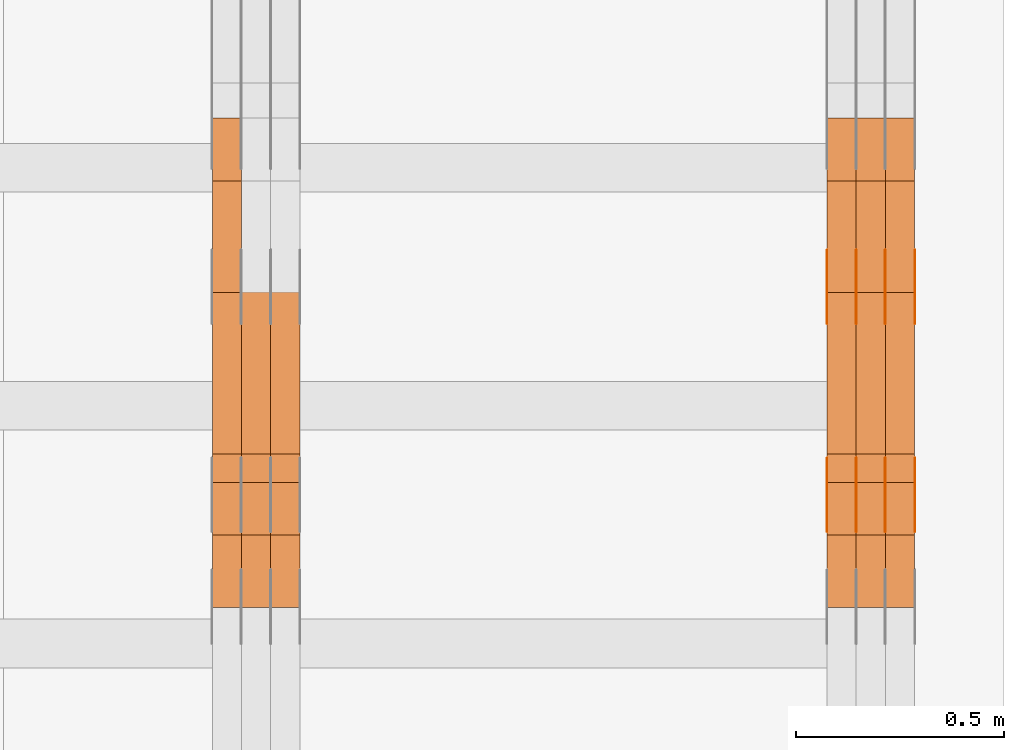
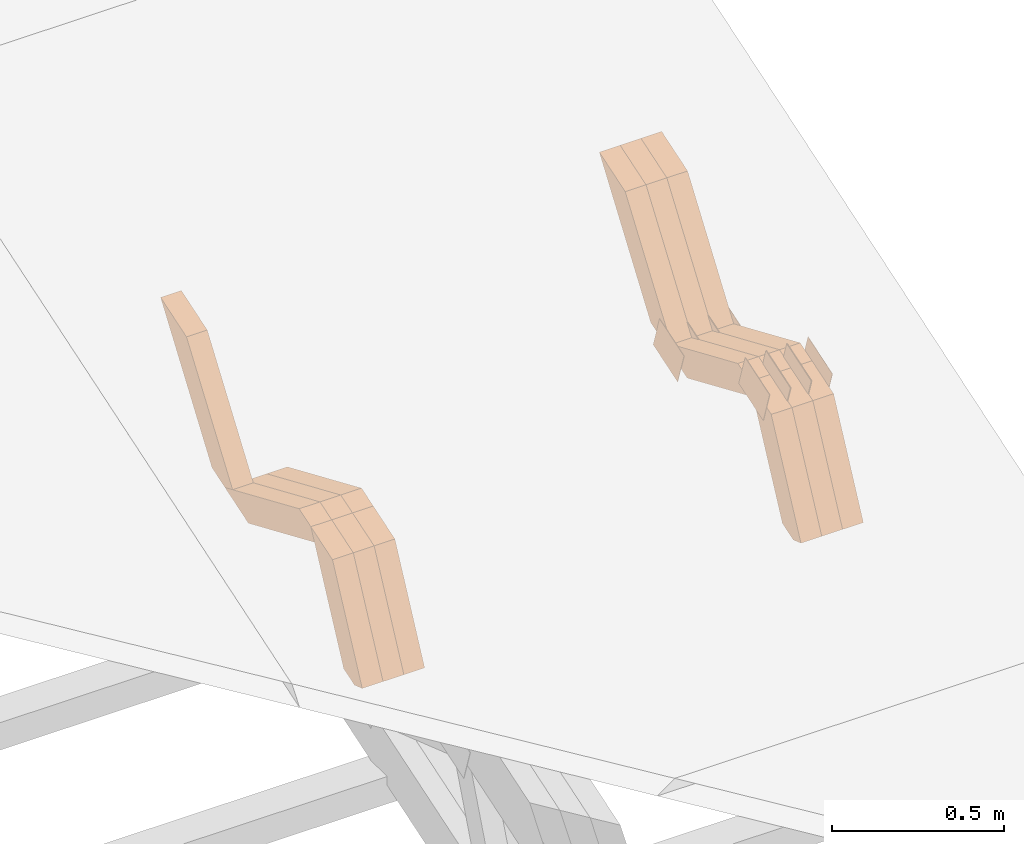
# One storey, part 313 of 385: 28 proxies.
"""IFC2X3 building model written with IfcOpenShell, lengths in millimetres."""

from ifc_helpers import new_model, entity, si_unit, converted_unit, derived_unit, direction, frame, origin, place, context, subcontext, project, spatial, polyline, outline, extrude, source, transform, mapped, material, type_object, type_shapes, element, save


model = new_model("IFC2X3")

# Units and contexts
model_context = context("Model", 3, precision=0.01, world=origin(), true_north=direction((6.12303176911189e-17, 1.0)))
body_context = subcontext(model_context, "Body", "Model", "MODEL_VIEW")
ifc_project = project(units=[si_unit("LENGTHUNIT", "METRE", prefix="MILLI"), si_unit("AREAUNIT", "SQUARE_METRE"), si_unit("VOLUMEUNIT", "CUBIC_METRE"), converted_unit("PLANEANGLEUNIT", "DEGREE", entity("IfcRatioMeasure", 0.0174532925199433), si_unit("PLANEANGLEUNIT", "RADIAN"), dimensions=[0, 0, 0, 0, 0, 0, 0]), si_unit("MASSUNIT", "GRAM", prefix="KILO"), derived_unit("MASSDENSITYUNIT", [(si_unit("MASSUNIT", "GRAM", prefix="KILO"), 1), (si_unit("LENGTHUNIT", "METRE"), -3)]), si_unit("TIMEUNIT", "SECOND"), si_unit("FREQUENCYUNIT", "HERTZ"), si_unit("THERMODYNAMICTEMPERATUREUNIT", "DEGREE_CELSIUS"), derived_unit("THERMALTRANSMITTANCEUNIT", [(si_unit("MASSUNIT", "GRAM", prefix="KILO"), 1), (si_unit("THERMODYNAMICTEMPERATUREUNIT", "KELVIN"), -1), (si_unit("TIMEUNIT", "SECOND"), -3)]), derived_unit("VOLUMETRICFLOWRATEUNIT", [(si_unit("LENGTHUNIT", "METRE"), 3), (si_unit("TIMEUNIT", "SECOND"), -1)]), si_unit("ELECTRICCURRENTUNIT", "AMPERE"), si_unit("ELECTRICVOLTAGEUNIT", "VOLT"), si_unit("POWERUNIT", "WATT"), si_unit("FORCEUNIT", "NEWTON", prefix="KILO"), si_unit("ILLUMINANCEUNIT", "LUX"), si_unit("LUMINOUSFLUXUNIT", "LUMEN"), si_unit("LUMINOUSINTENSITYUNIT", "CANDELA"), derived_unit("USERDEFINED", [(si_unit("MASSUNIT", "GRAM", prefix="KILO"), -1), (si_unit("LENGTHUNIT", "METRE"), -2), (si_unit("TIMEUNIT", "SECOND"), 3), (si_unit("LUMINOUSFLUXUNIT", "LUMEN"), 1)]), derived_unit("LINEARVELOCITYUNIT", [(si_unit("LENGTHUNIT", "METRE"), 1), (si_unit("TIMEUNIT", "SECOND"), -1)]), si_unit("PRESSUREUNIT", "PASCAL"), derived_unit("USERDEFINED", [(si_unit("LENGTHUNIT", "METRE"), -2), (si_unit("MASSUNIT", "GRAM", prefix="KILO"), 1), (si_unit("TIMEUNIT", "SECOND"), -2)])], contexts=[model_context])

# Site, building, storey
site_placement = place(None, origin())
site = spatial("IfcSite", under=ifc_project, at=site_placement, CompositionType="ELEMENT")
building_placement = place(site_placement, origin())
building = spatial("IfcBuilding", under=site, at=building_placement, CompositionType="ELEMENT")
storey_placement = place(building_placement, origin())
storey = spatial("IfcBuildingStorey", under=building, at=storey_placement, Name="Default", CompositionType="ELEMENT", Elevation=0.0)

# Proxies
ifc_material_1 = material(Name="IfcSurfaceStyle #620956")
building_element_proxy_type_1 = type_object("IfcBuildingElementProxyType", PredefinedType="NOTDEFINED", material=ifc_material_1)
shared_shape_1 = source(origin(), body_context, "Body", "SweptSolid", [
    extrude(outline(polyline([(-74.9998565677169, -60.0000596852269), (74.9998794200137, -60.0000596852269), (74.9998565677151, 60.0000596852269), (-74.9998794200119, 60.0000596852269), (-74.9998565677169, -60.0000596852269)])), frame((74.9998794200137, 60.0000596852269, 0.0), z_axis=(0.0, 0.0, 1.0), x_axis=(-1.0, 0.0, 0.0)), (0.0, 0.0, 1.0), 1.3),
])
type_shapes(building_element_proxy_type_1, [shared_shape_1])
proxy_1_placement = place(building_placement, frame((49861.3, 7527.6269081625, 1621.97418552253), z_axis=(-1.0, 0.0, 0.0), x_axis=(0.0, 0.951056516295124, 0.309016994375039)))
element("IfcBuildingElementProxy", 1, at=proxy_1_placement, inside=storey, type_object=building_element_proxy_type_1, material=ifc_material_1, context=body_context, shape_type="MappedRepresentation", body=[
    mapped(shared_shape_1, transform((0.0, 0.0, 0.0), scale=1.0)),
])
ifc_material_2 = material(Name="IfcSurfaceStyle #620899")
building_element_proxy_type_2 = type_object("IfcBuildingElementProxyType", PredefinedType="NOTDEFINED", material=ifc_material_2)
shared_shape_2 = source(origin(), body_context, "Body", "SweptSolid", [
    extrude(outline(polyline([(-74.9998565677169, -60.0000596852269), (74.9998794200137, -60.0000596852269), (74.9998565677151, 60.0000596852269), (-74.9998794200119, 60.0000596852269), (-74.9998565677169, -60.0000596852269)])), frame((74.9998794200137, 60.0000596852269, 0.0), z_axis=(0.0, 0.0, 1.0), x_axis=(-1.0, 0.0, 0.0)), (0.0, 0.0, 1.0), 1.3),
])
type_shapes(building_element_proxy_type_2, [shared_shape_2])
proxy_2_placement = place(building_placement, frame((49790.0, 7527.6269081625, 1621.97418552253), z_axis=(-1.0, 0.0, 0.0), x_axis=(0.0, 0.951056516295124, 0.309016994375039)))
element("IfcBuildingElementProxy", 2, at=proxy_2_placement, inside=storey, type_object=building_element_proxy_type_2, material=ifc_material_2, context=body_context, shape_type="MappedRepresentation", body=[
    mapped(shared_shape_2, transform((0.0, 0.0, 0.0), scale=1.0)),
])
ifc_material_3 = material(Name="IfcSurfaceStyle #620842")
building_element_proxy_type_3 = type_object("IfcBuildingElementProxyType", PredefinedType="NOTDEFINED", material=ifc_material_3)
shared_shape_3 = source(origin(), body_context, "Body", "SweptSolid", [
    extrude(outline(polyline([(-74.9998565677169, -60.0000596852269), (74.9998794200137, -60.0000596852269), (74.9998565677151, 60.0000596852269), (-74.9998794200119, 60.0000596852269), (-74.9998565677169, -60.0000596852269)])), frame((74.9998794200137, 60.0000596852269, 0.0), z_axis=(0.0, 0.0, 1.0), x_axis=(-1.0, 0.0, 0.0)), (0.0, 0.0, 1.0), 1.3),
])
type_shapes(building_element_proxy_type_3, [shared_shape_3])
proxy_3_placement = place(building_placement, frame((49791.3, 7527.6269081625, 1621.97418552253), z_axis=(-1.0, 0.0, 0.0), x_axis=(0.0, 0.951056516295124, 0.309016994375039)))
element("IfcBuildingElementProxy", 3, at=proxy_3_placement, inside=storey, type_object=building_element_proxy_type_3, material=ifc_material_3, context=body_context, shape_type="MappedRepresentation", body=[
    mapped(shared_shape_3, transform((0.0, 0.0, 0.0), scale=1.0)),
])
ifc_material_4 = material(Name="IfcSurfaceStyle #620785")
building_element_proxy_type_4 = type_object("IfcBuildingElementProxyType", PredefinedType="NOTDEFINED", material=ifc_material_4)
shared_shape_4 = source(origin(), body_context, "Body", "SweptSolid", [
    extrude(outline(polyline([(-74.9998565677169, -60.0000596852269), (74.9998794200137, -60.0000596852269), (74.9998565677151, 60.0000596852269), (-74.9998794200119, 60.0000596852269), (-74.9998565677169, -60.0000596852269)])), frame((74.9998794200137, 60.0000596852269, 0.0), z_axis=(0.0, 0.0, 1.0), x_axis=(-1.0, 0.0, 0.0)), (0.0, 0.0, 1.0), 1.29999999999999),
])
type_shapes(building_element_proxy_type_4, [shared_shape_4])
proxy_4_placement = place(building_placement, frame((49720.0, 7527.6269081625, 1621.97418552253), z_axis=(-1.0, 0.0, 0.0), x_axis=(0.0, 0.951056516295124, 0.309016994375039)))
element("IfcBuildingElementProxy", 4, at=proxy_4_placement, inside=storey, type_object=building_element_proxy_type_4, material=ifc_material_4, context=body_context, shape_type="MappedRepresentation", body=[
    mapped(shared_shape_4, transform((0.0, 0.0, 0.0), scale=1.0)),
])
ifc_material_5 = material(Name="IfcSurfaceStyle #620728")
building_element_proxy_type_5 = type_object("IfcBuildingElementProxyType", PredefinedType="NOTDEFINED", material=ifc_material_5)
shared_shape_5 = source(origin(), body_context, "Body", "SweptSolid", [
    extrude(outline(polyline([(-74.9998565677169, -60.0000596852269), (74.9998794200137, -60.0000596852269), (74.9998565677151, 60.0000596852269), (-74.9998794200119, 60.0000596852269), (-74.9998565677169, -60.0000596852269)])), frame((74.9998794200137, 60.0000596852269, 0.0), z_axis=(0.0, 0.0, 1.0), x_axis=(-1.0, 0.0, 0.0)), (0.0, 0.0, 1.0), 1.29999999999999),
])
type_shapes(building_element_proxy_type_5, [shared_shape_5])
proxy_5_placement = place(building_placement, frame((49721.3, 7527.6269081625, 1621.97418552253), z_axis=(-1.0, 0.0, 0.0), x_axis=(0.0, 0.951056516295124, 0.309016994375039)))
element("IfcBuildingElementProxy", 5, at=proxy_5_placement, inside=storey, type_object=building_element_proxy_type_5, material=ifc_material_5, context=body_context, shape_type="MappedRepresentation", body=[
    mapped(shared_shape_5, transform((0.0, 0.0, 0.0), scale=1.0)),
])
ifc_material_6 = material(Name="IfcSurfaceStyle #620671")
building_element_proxy_type_6 = type_object("IfcBuildingElementProxyType", PredefinedType="NOTDEFINED", material=ifc_material_6)
shared_shape_6 = source(origin(), body_context, "Body", "SweptSolid", [
    extrude(outline(polyline([(-74.9998565677169, -60.0000596852269), (74.9998794200137, -60.0000596852269), (74.9998565677151, 60.0000596852269), (-74.9998794200119, 60.0000596852269), (-74.9998565677169, -60.0000596852269)])), frame((74.9998794200137, 60.0000596852269, 0.0), z_axis=(0.0, 0.0, 1.0), x_axis=(-1.0, 0.0, 0.0)), (0.0, 0.0, 1.0), 1.29999999999999),
])
type_shapes(building_element_proxy_type_6, [shared_shape_6])
proxy_6_placement = place(building_placement, frame((49650.0, 7527.6269081625, 1621.97418552253), z_axis=(-1.0, 0.0, 0.0), x_axis=(0.0, 0.951056516295124, 0.309016994375039)))
element("IfcBuildingElementProxy", 6, at=proxy_6_placement, inside=storey, type_object=building_element_proxy_type_6, material=ifc_material_6, context=body_context, shape_type="MappedRepresentation", body=[
    mapped(shared_shape_6, transform((0.0, 0.0, 0.0), scale=1.0)),
])
ifc_material_7 = material(Name="IfcSurfaceStyle #610696")
building_element_proxy_type_7 = type_object("IfcBuildingElementProxyType", PredefinedType="NOTDEFINED", material=ifc_material_7)
shared_shape_7 = source(origin(), body_context, "Body", "SweptSolid", [
    extrude(outline(polyline([(-74.9998565677233, -60.0000596852342), (74.9998794200074, -60.0000596852342), (74.9998565677233, 60.0000596852342), (-74.9998794200074, 60.0000596852342), (-74.9998565677233, -60.0000596852342)])), frame((74.9998794200073, 60.0000596852342, 0.0), z_axis=(0.0, 0.0, 1.0), x_axis=(-1.0, 0.0, 0.0)), (0.0, 0.0, 1.0), 1.3),
])
type_shapes(building_element_proxy_type_7, [shared_shape_7])
proxy_7_placement = place(building_placement, frame((49861.3, 7029.15620503751, 1786.70025974129), z_axis=(-1.0, 0.0, 0.0), x_axis=(0.0, 0.951056516295154, 0.309016994374948)))
element("IfcBuildingElementProxy", 7, at=proxy_7_placement, inside=storey, type_object=building_element_proxy_type_7, material=ifc_material_7, context=body_context, shape_type="MappedRepresentation", body=[
    mapped(shared_shape_7, transform((0.0, 0.0, 0.0), scale=1.0)),
])
ifc_material_8 = material(Name="IfcSurfaceStyle #610639")
building_element_proxy_type_8 = type_object("IfcBuildingElementProxyType", PredefinedType="NOTDEFINED", material=ifc_material_8)
shared_shape_8 = source(origin(), body_context, "Body", "SweptSolid", [
    extrude(outline(polyline([(-74.9998565677233, -60.0000596852342), (74.9998794200074, -60.0000596852342), (74.9998565677233, 60.0000596852342), (-74.9998794200074, 60.0000596852342), (-74.9998565677233, -60.0000596852342)])), frame((74.9998794200073, 60.0000596852342, 0.0), z_axis=(0.0, 0.0, 1.0), x_axis=(-1.0, 0.0, 0.0)), (0.0, 0.0, 1.0), 1.3),
])
type_shapes(building_element_proxy_type_8, [shared_shape_8])
proxy_8_placement = place(building_placement, frame((49790.0, 7029.15620503751, 1786.70025974129), z_axis=(-1.0, 0.0, 0.0), x_axis=(0.0, 0.951056516295154, 0.309016994374948)))
element("IfcBuildingElementProxy", 8, at=proxy_8_placement, inside=storey, type_object=building_element_proxy_type_8, material=ifc_material_8, context=body_context, shape_type="MappedRepresentation", body=[
    mapped(shared_shape_8, transform((0.0, 0.0, 0.0), scale=1.0)),
])
ifc_material_9 = material(Name="IfcSurfaceStyle #610582")
building_element_proxy_type_9 = type_object("IfcBuildingElementProxyType", PredefinedType="NOTDEFINED", material=ifc_material_9)
shared_shape_9 = source(origin(), body_context, "Body", "SweptSolid", [
    extrude(outline(polyline([(-74.9998565677233, -60.0000596852342), (74.9998794200074, -60.0000596852342), (74.9998565677233, 60.0000596852342), (-74.9998794200074, 60.0000596852342), (-74.9998565677233, -60.0000596852342)])), frame((74.9998794200073, 60.0000596852342, 0.0), z_axis=(0.0, 0.0, 1.0), x_axis=(-1.0, 0.0, 0.0)), (0.0, 0.0, 1.0), 1.3),
])
type_shapes(building_element_proxy_type_9, [shared_shape_9])
proxy_9_placement = place(building_placement, frame((49791.3, 7029.15620503751, 1786.70025974129), z_axis=(-1.0, 0.0, 0.0), x_axis=(0.0, 0.951056516295154, 0.309016994374948)))
element("IfcBuildingElementProxy", 9, at=proxy_9_placement, inside=storey, type_object=building_element_proxy_type_9, material=ifc_material_9, context=body_context, shape_type="MappedRepresentation", body=[
    mapped(shared_shape_9, transform((0.0, 0.0, 0.0), scale=1.0)),
])
ifc_material_10 = material(Name="IfcSurfaceStyle #610525")
building_element_proxy_type_10 = type_object("IfcBuildingElementProxyType", PredefinedType="NOTDEFINED", material=ifc_material_10)
shared_shape_10 = source(origin(), body_context, "Body", "SweptSolid", [
    extrude(outline(polyline([(-74.9998565677233, -60.0000596852342), (74.9998794200074, -60.0000596852342), (74.9998565677233, 60.0000596852342), (-74.9998794200074, 60.0000596852342), (-74.9998565677233, -60.0000596852342)])), frame((74.9998794200073, 60.0000596852342, 0.0), z_axis=(0.0, 0.0, 1.0), x_axis=(-1.0, 0.0, 0.0)), (0.0, 0.0, 1.0), 1.29999999999999),
])
type_shapes(building_element_proxy_type_10, [shared_shape_10])
proxy_10_placement = place(building_placement, frame((49720.0, 7029.15620503751, 1786.70025974129), z_axis=(-1.0, 0.0, 0.0), x_axis=(0.0, 0.951056516295154, 0.309016994374948)))
element("IfcBuildingElementProxy", 10, at=proxy_10_placement, inside=storey, type_object=building_element_proxy_type_10, material=ifc_material_10, context=body_context, shape_type="MappedRepresentation", body=[
    mapped(shared_shape_10, transform((0.0, 0.0, 0.0), scale=1.0)),
])
ifc_material_11 = material(Name="IfcSurfaceStyle #610468")
building_element_proxy_type_11 = type_object("IfcBuildingElementProxyType", PredefinedType="NOTDEFINED", material=ifc_material_11)
shared_shape_11 = source(origin(), body_context, "Body", "SweptSolid", [
    extrude(outline(polyline([(-74.9998565677233, -60.0000596852342), (74.9998794200074, -60.0000596852342), (74.9998565677233, 60.0000596852342), (-74.9998794200074, 60.0000596852342), (-74.9998565677233, -60.0000596852342)])), frame((74.9998794200073, 60.0000596852342, 0.0), z_axis=(0.0, 0.0, 1.0), x_axis=(-1.0, 0.0, 0.0)), (0.0, 0.0, 1.0), 1.29999999999999),
])
type_shapes(building_element_proxy_type_11, [shared_shape_11])
proxy_11_placement = place(building_placement, frame((49721.3, 7029.15620503751, 1786.70025974129), z_axis=(-1.0, 0.0, 0.0), x_axis=(0.0, 0.951056516295154, 0.309016994374948)))
element("IfcBuildingElementProxy", 11, at=proxy_11_placement, inside=storey, type_object=building_element_proxy_type_11, material=ifc_material_11, context=body_context, shape_type="MappedRepresentation", body=[
    mapped(shared_shape_11, transform((0.0, 0.0, 0.0), scale=1.0)),
])
ifc_material_12 = material(Name="IfcSurfaceStyle #610411")
building_element_proxy_type_12 = type_object("IfcBuildingElementProxyType", PredefinedType="NOTDEFINED", material=ifc_material_12)
shared_shape_12 = source(origin(), body_context, "Body", "SweptSolid", [
    extrude(outline(polyline([(-74.9998565677233, -60.0000596852342), (74.9998794200074, -60.0000596852342), (74.9998565677233, 60.0000596852342), (-74.9998794200074, 60.0000596852342), (-74.9998565677233, -60.0000596852342)])), frame((74.9998794200073, 60.0000596852342, 0.0), z_axis=(0.0, 0.0, 1.0), x_axis=(-1.0, 0.0, 0.0)), (0.0, 0.0, 1.0), 1.29999999999999),
])
type_shapes(building_element_proxy_type_12, [shared_shape_12])
proxy_12_placement = place(building_placement, frame((49650.0, 7029.15620503751, 1786.70025974129), z_axis=(-1.0, 0.0, 0.0), x_axis=(0.0, 0.951056516295154, 0.309016994374948)))
element("IfcBuildingElementProxy", 12, at=proxy_12_placement, inside=storey, type_object=building_element_proxy_type_12, material=ifc_material_12, context=body_context, shape_type="MappedRepresentation", body=[
    mapped(shared_shape_12, transform((0.0, 0.0, 0.0), scale=1.0)),
])
ifc_material_13 = material(Name="IfcSurfaceStyle #598204")
building_element_proxy_type_13 = type_object("IfcBuildingElementProxyType", Name="T2-W17 598202", PredefinedType="NOTDEFINED", material=ifc_material_13)
shared_shape_13 = source(origin(), body_context, "Body", "SweptSolid", [
    extrude(outline(polyline([(-364.271754334175, -47.5002955168173), (154.762247185537, -47.5002955168173), (218.32500198375, 4.1746158945366e-05), (228.330650189718, 47.5002746437378), (-237.14614502483, 47.5002746437378), (-364.271754334175, -47.5002955168173)])), frame((228.330650189718, 47.5002746437378, 0.0), z_axis=(0.0, 0.0, 1.0), x_axis=(-1.0, 0.0, 0.0)), (0.0, 0.0, 1.0), 70.0),
])
type_shapes(building_element_proxy_type_13, [shared_shape_13])
proxy_13_placement = place(building_placement, frame((49860.0, 7603.591796875, 1617.27880859375), z_axis=(-1.0, 0.0, 0.0), x_axis=(0.0, 0.576852646364743, 0.816848226038346)))
element("IfcBuildingElementProxy", 13, at=proxy_13_placement, inside=storey, type_object=building_element_proxy_type_13, material=ifc_material_13, Name="T2-W17", context=body_context, shape_type="MappedRepresentation", body=[
    mapped(shared_shape_13, transform((0.0, 0.0, 0.0), scale=1.0)),
])
ifc_material_14 = material(Name="IfcSurfaceStyle #598138")
building_element_proxy_type_14 = type_object("IfcBuildingElementProxyType", Name="T2-W17 598136", PredefinedType="NOTDEFINED", material=ifc_material_14)
shared_shape_14 = source(origin(), body_context, "Body", "SweptSolid", [
    extrude(outline(polyline([(-364.271754334175, -47.5002955168173), (154.762247185537, -47.5002955168173), (218.32500198375, 4.1746158945366e-05), (228.330650189718, 47.5002746437378), (-237.14614502483, 47.5002746437378), (-364.271754334175, -47.5002955168173)])), frame((228.330650189718, 47.5002746437378, 0.0), z_axis=(0.0, 0.0, 1.0), x_axis=(-1.0, 0.0, 0.0)), (0.0, 0.0, 1.0), 70.0),
])
type_shapes(building_element_proxy_type_14, [shared_shape_14])
proxy_14_placement = place(building_placement, frame((49790.0, 7603.591796875, 1617.27880859375), z_axis=(-1.0, 0.0, 0.0), x_axis=(0.0, 0.576852646364743, 0.816848226038346)))
element("IfcBuildingElementProxy", 14, at=proxy_14_placement, inside=storey, type_object=building_element_proxy_type_14, material=ifc_material_14, Name="T2-W17", context=body_context, shape_type="MappedRepresentation", body=[
    mapped(shared_shape_14, transform((0.0, 0.0, 0.0), scale=1.0)),
])
ifc_material_15 = material(Name="IfcSurfaceStyle #598072")
building_element_proxy_type_15 = type_object("IfcBuildingElementProxyType", Name="T2-W17 598070", PredefinedType="NOTDEFINED", material=ifc_material_15)
shared_shape_15 = source(origin(), body_context, "Body", "SweptSolid", [
    extrude(outline(polyline([(-364.271754334175, -47.5002955168173), (154.762247185537, -47.5002955168173), (218.32500198375, 4.1746158945366e-05), (228.330650189718, 47.5002746437378), (-237.14614502483, 47.5002746437378), (-364.271754334175, -47.5002955168173)])), frame((228.330650189718, 47.5002746437378, 0.0), z_axis=(0.0, 0.0, 1.0), x_axis=(-1.0, 0.0, 0.0)), (0.0, 0.0, 1.0), 70.0),
])
type_shapes(building_element_proxy_type_15, [shared_shape_15])
proxy_15_placement = place(building_placement, frame((49720.0, 7603.591796875, 1617.27880859375), z_axis=(-1.0, 0.0, 0.0), x_axis=(0.0, 0.576852646364743, 0.816848226038346)))
element("IfcBuildingElementProxy", 15, at=proxy_15_placement, inside=storey, type_object=building_element_proxy_type_15, material=ifc_material_15, Name="T2-W17", context=body_context, shape_type="MappedRepresentation", body=[
    mapped(shared_shape_15, transform((0.0, 0.0, 0.0), scale=1.0)),
])
ifc_material_16 = material(Name="IfcSurfaceStyle #597808")
building_element_proxy_type_16 = type_object("IfcBuildingElementProxyType", Name="T2-W28 597806", PredefinedType="NOTDEFINED", material=ifc_material_16)
shared_shape_16 = source(origin(), body_context, "Body", "SweptSolid", [
    extrude(outline(polyline([(-217.926999432742, -47.5002417204892), (200.85556309928, -47.5002417204892), (198.503183549447, 8.27993157516647e-05), (144.500539771884, 47.5002003208314), (-325.932286987868, 47.5002003208314), (-217.926999432742, -47.5002417204892)])), frame((200.855855188284, 47.5002003208314, 0.0), z_axis=(0.0, 0.0, 1.0), x_axis=(-1.0, 0.0, 0.0)), (0.0, 0.0, 1.0), 70.0),
])
type_shapes(building_element_proxy_type_16, [shared_shape_16])
proxy_16_placement = place(building_placement, frame((49860.0, 7164.46308589723, 1806.71154838415), z_axis=(-1.0, 0.0, 0.0), x_axis=(0.0, 0.918207947119617, -0.396098681954861)))
element("IfcBuildingElementProxy", 16, at=proxy_16_placement, inside=storey, type_object=building_element_proxy_type_16, material=ifc_material_16, Name="T2-W28", context=body_context, shape_type="MappedRepresentation", body=[
    mapped(shared_shape_16, transform((0.0, 0.0, 0.0), scale=1.0)),
])
ifc_material_17 = material(Name="IfcSurfaceStyle #597742")
building_element_proxy_type_17 = type_object("IfcBuildingElementProxyType", Name="T2-W28 597740", PredefinedType="NOTDEFINED", material=ifc_material_17)
shared_shape_17 = source(origin(), body_context, "Body", "SweptSolid", [
    extrude(outline(polyline([(-217.926999432742, -47.5002417204892), (200.85556309928, -47.5002417204892), (198.503183549447, 8.27993157516647e-05), (144.500539771884, 47.5002003208314), (-325.932286987868, 47.5002003208314), (-217.926999432742, -47.5002417204892)])), frame((200.855855188284, 47.5002003208314, 0.0), z_axis=(0.0, 0.0, 1.0), x_axis=(-1.0, 0.0, 0.0)), (0.0, 0.0, 1.0), 70.0),
])
type_shapes(building_element_proxy_type_17, [shared_shape_17])
proxy_17_placement = place(building_placement, frame((49790.0, 7164.46308589723, 1806.71154838415), z_axis=(-1.0, 0.0, 0.0), x_axis=(0.0, 0.918207947119617, -0.396098681954861)))
element("IfcBuildingElementProxy", 17, at=proxy_17_placement, inside=storey, type_object=building_element_proxy_type_17, material=ifc_material_17, Name="T2-W28", context=body_context, shape_type="MappedRepresentation", body=[
    mapped(shared_shape_17, transform((0.0, 0.0, 0.0), scale=1.0)),
])
ifc_material_18 = material(Name="IfcSurfaceStyle #597676")
building_element_proxy_type_18 = type_object("IfcBuildingElementProxyType", Name="T2-W28 597674", PredefinedType="NOTDEFINED", material=ifc_material_18)
shared_shape_18 = source(origin(), body_context, "Body", "SweptSolid", [
    extrude(outline(polyline([(-217.926999432742, -47.5002417204892), (200.85556309928, -47.5002417204892), (198.503183549447, 8.27993157516647e-05), (144.500539771884, 47.5002003208314), (-325.932286987868, 47.5002003208314), (-217.926999432742, -47.5002417204892)])), frame((200.855855188284, 47.5002003208314, 0.0), z_axis=(0.0, 0.0, 1.0), x_axis=(-1.0, 0.0, 0.0)), (0.0, 0.0, 1.0), 70.0),
])
type_shapes(building_element_proxy_type_18, [shared_shape_18])
proxy_18_placement = place(building_placement, frame((49720.0, 7164.46308589723, 1806.71154838415), z_axis=(-1.0, 0.0, 0.0), x_axis=(0.0, 0.918207947119617, -0.396098681954861)))
element("IfcBuildingElementProxy", 18, at=proxy_18_placement, inside=storey, type_object=building_element_proxy_type_18, material=ifc_material_18, Name="T2-W28", context=body_context, shape_type="MappedRepresentation", body=[
    mapped(shared_shape_18, transform((0.0, 0.0, 0.0), scale=1.0)),
])
ifc_material_19 = material(Name="IfcSurfaceStyle #597412")
building_element_proxy_type_19 = type_object("IfcBuildingElementProxyType", Name="T2-W38 597410", PredefinedType="NOTDEFINED", material=ifc_material_19)
shared_shape_19 = source(origin(), body_context, "Body", "SweptSolid", [
    extrude(outline(polyline([(-298.027186733919, -47.5000251939178), (135.138415004037, -47.5000251939178), (181.282052802132, 0.000918984287993996), (187.347601017465, 47.4995657017738), (-205.740882089715, 47.4995657017739), (-298.027186733919, -47.5000251939178)])), frame((187.347846776827, 47.5001085012031, 0.0), z_axis=(0.0, 0.0, 1.0), x_axis=(-1.0, 0.0, 0.0)), (0.0, 0.0, 1.0), 70.0),
])
type_shapes(building_element_proxy_type_19, [shared_shape_19])
proxy_19_placement = place(building_placement, frame((49860.0, 6848.47987320449, 1368.44362234215), z_axis=(-1.0, 0.0, 0.0), x_axis=(0.0, 0.441034274474743, 0.897490261082836)))
element("IfcBuildingElementProxy", 19, at=proxy_19_placement, inside=storey, type_object=building_element_proxy_type_19, material=ifc_material_19, Name="T2-W38", context=body_context, shape_type="MappedRepresentation", body=[
    mapped(shared_shape_19, transform((0.0, 0.0, 0.0), scale=1.0)),
])
ifc_material_20 = material(Name="IfcSurfaceStyle #597346")
building_element_proxy_type_20 = type_object("IfcBuildingElementProxyType", Name="T2-W38 597344", PredefinedType="NOTDEFINED", material=ifc_material_20)
shared_shape_20 = source(origin(), body_context, "Body", "SweptSolid", [
    extrude(outline(polyline([(-298.027186733919, -47.5000251939178), (135.138415004037, -47.5000251939178), (181.282052802132, 0.000918984287993996), (187.347601017465, 47.4995657017738), (-205.740882089715, 47.4995657017739), (-298.027186733919, -47.5000251939178)])), frame((187.347846776827, 47.5001085012031, 0.0), z_axis=(0.0, 0.0, 1.0), x_axis=(-1.0, 0.0, 0.0)), (0.0, 0.0, 1.0), 70.0),
])
type_shapes(building_element_proxy_type_20, [shared_shape_20])
proxy_20_placement = place(building_placement, frame((49790.0, 6848.47987320449, 1368.44362234215), z_axis=(-1.0, 0.0, 0.0), x_axis=(0.0, 0.441034274474743, 0.897490261082836)))
element("IfcBuildingElementProxy", 20, at=proxy_20_placement, inside=storey, type_object=building_element_proxy_type_20, material=ifc_material_20, Name="T2-W38", context=body_context, shape_type="MappedRepresentation", body=[
    mapped(shared_shape_20, transform((0.0, 0.0, 0.0), scale=1.0)),
])
ifc_material_21 = material(Name="IfcSurfaceStyle #597280")
building_element_proxy_type_21 = type_object("IfcBuildingElementProxyType", Name="T2-W38 597278", PredefinedType="NOTDEFINED", material=ifc_material_21)
shared_shape_21 = source(origin(), body_context, "Body", "SweptSolid", [
    extrude(outline(polyline([(-298.027186733919, -47.5000251939178), (135.138415004037, -47.5000251939178), (181.282052802132, 0.000918984287993996), (187.347601017465, 47.4995657017738), (-205.740882089715, 47.4995657017739), (-298.027186733919, -47.5000251939178)])), frame((187.347846776827, 47.5001085012031, 0.0), z_axis=(0.0, 0.0, 1.0), x_axis=(-1.0, 0.0, 0.0)), (0.0, 0.0, 1.0), 70.0),
])
type_shapes(building_element_proxy_type_21, [shared_shape_21])
proxy_21_placement = place(building_placement, frame((49720.0, 6848.47987320449, 1368.44362234215), z_axis=(-1.0, 0.0, 0.0), x_axis=(0.0, 0.441034274474743, 0.897490261082836)))
element("IfcBuildingElementProxy", 21, at=proxy_21_placement, inside=storey, type_object=building_element_proxy_type_21, material=ifc_material_21, Name="T2-W38", context=body_context, shape_type="MappedRepresentation", body=[
    mapped(shared_shape_21, transform((0.0, 0.0, 0.0), scale=1.0)),
])
ifc_material_22 = material(Name="IfcSurfaceStyle #563640")
building_element_proxy_type_22 = type_object("IfcBuildingElementProxyType", Name="T1-W17 563638", PredefinedType="NOTDEFINED", material=ifc_material_22)
shared_shape_22 = source(origin(), body_context, "Body", "SweptSolid", [
    extrude(outline(polyline([(-364.271754334175, -47.5002955168173), (154.762247185537, -47.5002955168173), (218.32500198375, 4.1746158945366e-05), (228.330650189718, 47.5002746437378), (-237.14614502483, 47.5002746437378), (-364.271754334175, -47.5002955168173)])), frame((228.330650189718, 47.5002746437378, 0.0), z_axis=(0.0, 0.0, 1.0), x_axis=(-1.0, 0.0, 0.0)), (0.0, 0.0, 1.0), 70.0),
])
type_shapes(building_element_proxy_type_22, [shared_shape_22])
proxy_22_placement = place(building_placement, frame((48245.0, 7603.59179687501, 1617.27880859375), z_axis=(-1.0, 0.0, 0.0), x_axis=(0.0, 0.576852646364743, 0.816848226038346)))
element("IfcBuildingElementProxy", 22, at=proxy_22_placement, inside=storey, type_object=building_element_proxy_type_22, material=ifc_material_22, Name="T1-W17", context=body_context, shape_type="MappedRepresentation", body=[
    mapped(shared_shape_22, transform((0.0, 0.0, 0.0), scale=1.0)),
])
ifc_material_23 = material(Name="IfcSurfaceStyle #563376")
building_element_proxy_type_23 = type_object("IfcBuildingElementProxyType", Name="T1-W28 563374", PredefinedType="NOTDEFINED", material=ifc_material_23)
shared_shape_23 = source(origin(), body_context, "Body", "SweptSolid", [
    extrude(outline(polyline([(-217.926999432742, -47.5002417204892), (200.85556309928, -47.5002417204892), (198.503183549447, 8.27993157516647e-05), (144.500539771884, 47.5002003208314), (-325.932286987868, 47.5002003208314), (-217.926999432742, -47.5002417204892)])), frame((200.855855188284, 47.5002003208314, 0.0), z_axis=(0.0, 0.0, 1.0), x_axis=(-1.0, 0.0, 0.0)), (0.0, 0.0, 1.0), 70.0),
])
type_shapes(building_element_proxy_type_23, [shared_shape_23])
proxy_23_placement = place(building_placement, frame((48385.0, 7164.46308589724, 1806.71154838415), z_axis=(-1.0, 0.0, 0.0), x_axis=(0.0, 0.918207947119617, -0.396098681954861)))
element("IfcBuildingElementProxy", 23, at=proxy_23_placement, inside=storey, type_object=building_element_proxy_type_23, material=ifc_material_23, Name="T1-W28", context=body_context, shape_type="MappedRepresentation", body=[
    mapped(shared_shape_23, transform((0.0, 0.0, 0.0), scale=1.0)),
])
ifc_material_24 = material(Name="IfcSurfaceStyle #563310")
building_element_proxy_type_24 = type_object("IfcBuildingElementProxyType", Name="T1-W28 563308", PredefinedType="NOTDEFINED", material=ifc_material_24)
shared_shape_24 = source(origin(), body_context, "Body", "SweptSolid", [
    extrude(outline(polyline([(-217.926999432742, -47.5002417204892), (200.85556309928, -47.5002417204892), (198.503183549447, 8.27993157516647e-05), (144.500539771884, 47.5002003208314), (-325.932286987868, 47.5002003208314), (-217.926999432742, -47.5002417204892)])), frame((200.855855188284, 47.5002003208314, 0.0), z_axis=(0.0, 0.0, 1.0), x_axis=(-1.0, 0.0, 0.0)), (0.0, 0.0, 1.0), 70.0),
])
type_shapes(building_element_proxy_type_24, [shared_shape_24])
proxy_24_placement = place(building_placement, frame((48315.0, 7164.46308589724, 1806.71154838415), z_axis=(-1.0, 0.0, 0.0), x_axis=(0.0, 0.918207947119617, -0.396098681954861)))
element("IfcBuildingElementProxy", 24, at=proxy_24_placement, inside=storey, type_object=building_element_proxy_type_24, material=ifc_material_24, Name="T1-W28", context=body_context, shape_type="MappedRepresentation", body=[
    mapped(shared_shape_24, transform((0.0, 0.0, 0.0), scale=1.0)),
])
ifc_material_25 = material(Name="IfcSurfaceStyle #563244")
building_element_proxy_type_25 = type_object("IfcBuildingElementProxyType", Name="T1-W28 563242", PredefinedType="NOTDEFINED", material=ifc_material_25)
shared_shape_25 = source(origin(), body_context, "Body", "SweptSolid", [
    extrude(outline(polyline([(-217.926999432742, -47.5002417204892), (200.85556309928, -47.5002417204892), (198.503183549447, 8.27993157516647e-05), (144.500539771884, 47.5002003208314), (-325.932286987868, 47.5002003208314), (-217.926999432742, -47.5002417204892)])), frame((200.855855188284, 47.5002003208314, 0.0), z_axis=(0.0, 0.0, 1.0), x_axis=(-1.0, 0.0, 0.0)), (0.0, 0.0, 1.0), 70.0),
])
type_shapes(building_element_proxy_type_25, [shared_shape_25])
proxy_25_placement = place(building_placement, frame((48245.0, 7164.46308589724, 1806.71154838415), z_axis=(-1.0, 0.0, 0.0), x_axis=(0.0, 0.918207947119617, -0.396098681954861)))
element("IfcBuildingElementProxy", 25, at=proxy_25_placement, inside=storey, type_object=building_element_proxy_type_25, material=ifc_material_25, Name="T1-W28", context=body_context, shape_type="MappedRepresentation", body=[
    mapped(shared_shape_25, transform((0.0, 0.0, 0.0), scale=1.0)),
])
ifc_material_26 = material(Name="IfcSurfaceStyle #562980")
building_element_proxy_type_26 = type_object("IfcBuildingElementProxyType", Name="T1-W38 562978", PredefinedType="NOTDEFINED", material=ifc_material_26)
shared_shape_26 = source(origin(), body_context, "Body", "SweptSolid", [
    extrude(outline(polyline([(-298.027186733919, -47.5000251939178), (135.138415004037, -47.5000251939178), (181.282052802132, 0.000918984287993996), (187.347601017465, 47.4995657017738), (-205.740882089715, 47.4995657017739), (-298.027186733919, -47.5000251939178)])), frame((187.347846776827, 47.5001085012031, 0.0), z_axis=(0.0, 0.0, 1.0), x_axis=(-1.0, 0.0, 0.0)), (0.0, 0.0, 1.0), 70.0),
])
type_shapes(building_element_proxy_type_26, [shared_shape_26])
proxy_26_placement = place(building_placement, frame((48385.0, 6848.4798732045, 1368.44362234215), z_axis=(-1.0, 0.0, 0.0), x_axis=(0.0, 0.441034274474743, 0.897490261082836)))
element("IfcBuildingElementProxy", 26, at=proxy_26_placement, inside=storey, type_object=building_element_proxy_type_26, material=ifc_material_26, Name="T1-W38", context=body_context, shape_type="MappedRepresentation", body=[
    mapped(shared_shape_26, transform((0.0, 0.0, 0.0), scale=1.0)),
])
ifc_material_27 = material(Name="IfcSurfaceStyle #562914")
building_element_proxy_type_27 = type_object("IfcBuildingElementProxyType", Name="T1-W38 562912", PredefinedType="NOTDEFINED", material=ifc_material_27)
shared_shape_27 = source(origin(), body_context, "Body", "SweptSolid", [
    extrude(outline(polyline([(-298.027186733919, -47.5000251939178), (135.138415004037, -47.5000251939178), (181.282052802132, 0.000918984287993996), (187.347601017465, 47.4995657017738), (-205.740882089715, 47.4995657017739), (-298.027186733919, -47.5000251939178)])), frame((187.347846776827, 47.5001085012031, 0.0), z_axis=(0.0, 0.0, 1.0), x_axis=(-1.0, 0.0, 0.0)), (0.0, 0.0, 1.0), 70.0),
])
type_shapes(building_element_proxy_type_27, [shared_shape_27])
proxy_27_placement = place(building_placement, frame((48315.0, 6848.4798732045, 1368.44362234215), z_axis=(-1.0, 0.0, 0.0), x_axis=(0.0, 0.441034274474743, 0.897490261082836)))
element("IfcBuildingElementProxy", 27, at=proxy_27_placement, inside=storey, type_object=building_element_proxy_type_27, material=ifc_material_27, Name="T1-W38", context=body_context, shape_type="MappedRepresentation", body=[
    mapped(shared_shape_27, transform((0.0, 0.0, 0.0), scale=1.0)),
])
ifc_material_28 = material(Name="IfcSurfaceStyle #562848")
building_element_proxy_type_28 = type_object("IfcBuildingElementProxyType", Name="T1-W38 562846", PredefinedType="NOTDEFINED", material=ifc_material_28)
shared_shape_28 = source(origin(), body_context, "Body", "SweptSolid", [
    extrude(outline(polyline([(-298.027186733919, -47.5000251939178), (135.138415004037, -47.5000251939178), (181.282052802132, 0.000918984287993996), (187.347601017465, 47.4995657017738), (-205.740882089715, 47.4995657017739), (-298.027186733919, -47.5000251939178)])), frame((187.347846776827, 47.5001085012031, 0.0), z_axis=(0.0, 0.0, 1.0), x_axis=(-1.0, 0.0, 0.0)), (0.0, 0.0, 1.0), 70.0),
])
type_shapes(building_element_proxy_type_28, [shared_shape_28])
proxy_28_placement = place(building_placement, frame((48245.0, 6848.4798732045, 1368.44362234215), z_axis=(-1.0, 0.0, 0.0), x_axis=(0.0, 0.441034274474743, 0.897490261082836)))
element("IfcBuildingElementProxy", 28, at=proxy_28_placement, inside=storey, type_object=building_element_proxy_type_28, material=ifc_material_28, Name="T1-W38", context=body_context, shape_type="MappedRepresentation", body=[
    mapped(shared_shape_28, transform((0.0, 0.0, 0.0), scale=1.0)),
])

save(model, "model.ifc")
